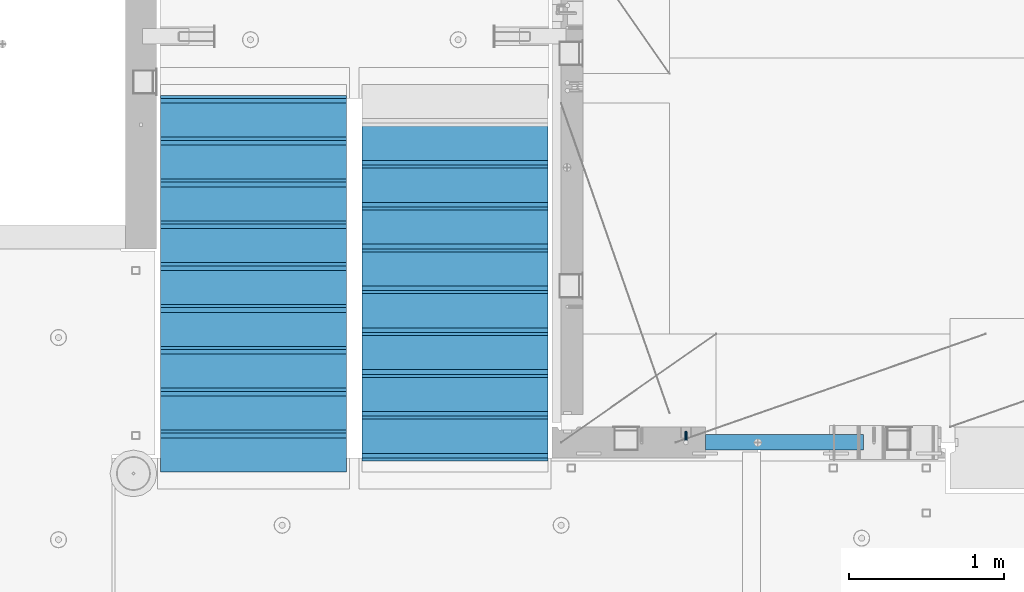
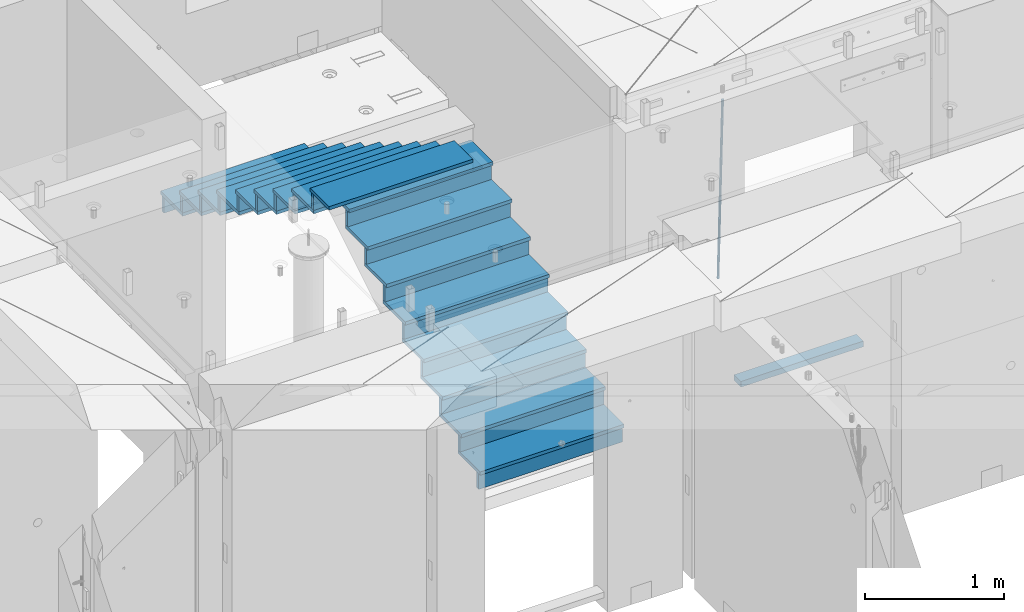
# One storey, part 119 of 350: 36 beams, 3 elements without a shape of their own.
"""IFC2X3 building model written with IfcOpenShell, lengths in millimetres."""

from ifc_helpers import new_model, si_unit, frame, origin_with_axes, place, context, subcontext, project, spatial, faceted_brep, material, type_object, element, aggregate, save


model = new_model("IFC2X3")

# Units and contexts
model_context = context("Model", 3, precision=1e-05, world=origin_with_axes())
body_context = subcontext(model_context, "Body", "Model", "MODEL_VIEW")
ifc_project = project(units=[si_unit("LENGTHUNIT", "METRE", prefix="MILLI"), si_unit("AREAUNIT", "SQUARE_METRE"), si_unit("VOLUMEUNIT", "CUBIC_METRE"), si_unit("MASSUNIT", "GRAM", prefix="KILO"), si_unit("TIMEUNIT", "SECOND"), si_unit("PLANEANGLEUNIT", "RADIAN"), si_unit("SOLIDANGLEUNIT", "STERADIAN"), si_unit("THERMODYNAMICTEMPERATUREUNIT", "DEGREE_CELSIUS"), si_unit("LUMINOUSINTENSITYUNIT", "LUMEN")], contexts=[model_context])

# Site, building, storey
site_placement = place(None, origin_with_axes())
site = spatial("IfcSite", under=ifc_project, at=site_placement, CompositionType="ELEMENT")
building_placement = place(site_placement, origin_with_axes())
building = spatial("IfcBuilding", under=site, at=building_placement, CompositionType="ELEMENT")
storey_placement = place(building_placement, origin_with_axes())
storey = spatial("IfcBuildingStorey", under=building, at=storey_placement, Name="2", CompositionType="ELEMENT", Elevation=0.0)

# Assembly, beams
assembly_1_placement = place(storey_placement, origin_with_axes())
assembly_1 = element("IfcElementAssembly", 1, at=assembly_1_placement, inside=storey, AssemblyPlace="NOTDEFINED", PredefinedType="REINFORCEMENT_UNIT")
ifc_material_1 = material()
beam_type_1 = type_object("IfcBeamType", Name="D20", PredefinedType="NOTDEFINED")
beam_1_placement = place(assembly_1_placement, frame((23075.0006866416, 17045.0000022791, 85790.0), z_axis=(0.00020576299992186, -0.999642804629538, -0.0267249099901004), x_axis=(-4.30000201928125e-08, -0.0267249099948059, 0.999642825806181)))
beam_1 = element("IfcBeam", 2, at=beam_1_placement, type_object=beam_type_1, material=ifc_material_1, Name="JM20", ObjectType="D20", context=body_context, shape_type="Brep", body=[
    faceted_brep([(0.0, -10.0, 0.0), (-4.19531716033816e-08, -7.07106781186667, -7.07106781187031), (60.4266690400545, -7.0710677960451, -7.07106780570757), (60.4266690441291, -9.99999998418934, 6.15546014159918e-09), (0.0, 0.0, -10.0), (60.426669036824, 1.58106558956206e-08, -9.99999999384454), (4.196772351861e-08, 7.07106781186303, -7.07106781186667), (60.4266690363438, 7.07106782768096, -7.07106780570757), (0.0, 10.0, 0.0), (60.4266690388904, 10.0000000158179, 6.15182216279209e-09), (4.196772351861e-08, 7.07106781185939, 7.07106781185939), (60.4266690429649, 7.07106782768096, 7.07106781802577), (0.0, 0.0, 10.0), (60.4266690461809, 1.58179318532348e-08, 10.0000000061555), (-4.19531716033816e-08, -7.07106781187031, 7.07106781185939), (60.4266690466611, -7.07106779605238, 7.07106781802213), (61.0378400410118, -7.07106779588503, -7.07106780564936), (60.991799419251, -9.99999998403655, 6.21366780251265e-09), (61.0569027789461, 1.5985278878361e-08, -9.99999999378269), (61.0378209396877, 7.07106782784831, -7.07106780564936), (60.9917724058905, 10.0000000159635, 6.21366780251265e-09), (60.9457317841297, 7.07106782781193, 7.0710678180767), (60.9266690461809, 1.59488990902901e-08, 10.0000000062028), (60.9457508854539, -7.07106779591413, 7.0710678180767), (61.6489592143771, -7.07106614513759, -7.06310863441468), (61.5568818710308, -9.9999984576425, 0.00735959856683621), (61.6870830769039, 1.71821739058942e-06, -9.99179257185824), (61.6489210170112, 7.07106947854481, -7.06310888312146), (61.556827851804, 10.0000015422847, 0.00735924683976918), (61.4647505084577, 7.07106922979438, 7.07782747982128), (61.4266266459163, 1.36643211590126e-06, 10.0065114172685), (61.464788705809, -7.07106639389531, 7.07782772852806), (176.543135720174, -7.07075579406956, -5.56673531796696), (176.451058376813, -9.99968810657447, 1.50373291501455), (176.581259582701, 0.000312069292704109, -8.49541925541052), (176.543097522794, 7.07137982961285, -5.56673556667374), (176.451004357587, 10.00031189336, 1.50373256329476), (176.35892701424, 7.07137958085514, 8.57420079627263), (176.320803151699, 0.000311717507429421, 11.5028847337162), (176.358965211621, -7.07075604281999, 8.57420104497578), (177.098753836006, -7.07075429323595, -5.55949898843028), (176.98362511232, -9.99968666800123, 1.510669025065), (177.146421932586, 0.000313595905026887, -8.48805862247536), (177.098706077581, 7.07138133041735, -5.55949936166144), (176.983557571715, 10.0003133318824, 1.51066849724157), (176.868428848029, 7.07138095712435, 8.58083651073321), (176.820760751449, 0.000313067976094317, 11.5093961447819), (176.868476606425, -7.07075466652896, 8.58083688396073), (177.654312950661, -7.07075204110879, -5.54863964998367), (177.516135294456, -9.99968450931192, 1.52107783331303), (177.711524267797, 0.000315886711177882, -8.47701274570863), (177.654255632195, 7.07138358250813, -5.54864021007961), (177.516054233929, 10.0003154905207, 1.5210770412159), (177.377876577739, 7.0713830223176, 8.59079452451624), (177.320665260588, 0.000315094497636892, 11.5191676202448), (177.377933896176, -7.07075260129932, 8.59079508461218), (299.580241614967, -7.07025777803938, -3.16539205229128), (299.442063958748, -9.99919024624614, 3.90432543100542), (299.637452932104, 0.000810149780591019, -6.09376514801625), (299.58018429653, 7.07187784557391, -3.16539261238358), (299.441982898265, 10.0008097535901, 3.90432463891557), (299.303805242045, 7.07187728538338, 10.974042122205), (299.246593924894, 0.00080935756341205, 13.9024152179336), (299.303862560482, -7.07025833822991, 10.9740426822973), (300.088882651282, -7.07025571611666, -3.15544980669438), (299.971788958996, -9.99918809853989, 3.91467979818117), (300.137357441272, 0.000812176291219657, -6.0839936725497), (300.088834180511, 7.07187990754028, -3.15545019384081), (299.971753863239, 10.0008119014747, 3.91467990454839), (299.854660170953, 7.07187951844026, 10.9848095094276), (299.806185380992, 0.000811626032373169, 13.9133533752902), (299.854708641738, -7.07025610520941, 10.9848098965813), (300.597573977022, -7.07025429077839, -3.14854421417112), (300.501599787152, -9.99918661431002, 3.92187219230618), (300.637311376035, 0.00081357714952901, -6.07720669196715), (300.597534354776, 7.07188133290401, -3.14854448120241), (300.501543752835, 10.0008133856099, 3.92187181466215), (300.40556956298, 7.07188106207104, 10.9922882211395), (300.365832163967, 0.000813194146758178, 13.9209506989318), (300.405609185211, -7.07025456160045, 10.9922884881707), (1494.60304651056, -7.06690872122999, 13.060333041718), (1494.50707232069, -9.99584104476162, 20.1307494481916), (1494.64278390956, 0.00415914670156781, 10.1316705639183), (1494.6030068883, 7.07522690244878, 13.0603327746867), (1494.50701628637, 10.004158955162, 20.1307490705476), (1494.4110420965, 7.07522663162308, 27.2011654770249), (1494.3713046975, 0.00415876370243495, 30.1298279548209), (1494.41108171875, -7.06690899205205, 27.2011657440526), (1495.1211563645, -7.06690726950183, 13.067366492749), (1495.00702625545, -9.99583964390331, 20.1375364287742), (1495.20660775043, 0.00416072652296862, 10.1393245920117), (1495.21332415029, 7.07522861253892, 13.0686179608165), (1495.13737118813, 10.0041607213934, 20.1393062718889), (1495.02324107911, 7.07522834699193, 27.2094762079141), (1494.93778969315, 0.00416035097441636, 30.1375181086514), (1494.93107329329, -7.06690753504881, 27.2082247398503), (1495.63922435709, -7.07365070849846, 13.0742491942874), (1495.5069397148, -10.00235861486, 20.1441724282631), (1495.77038591086, -0.00317370150150964, 10.1468279224828), (1495.82359171678, 7.06728286786529, 13.0767522910828), (1495.76767453534, 9.99594143344802, 20.1477123416917), (1495.63538989302, 7.0672335270865, 27.2176355756565), (1495.50422833927, -0.00324347991045215, 30.1450568474684), (1495.45102253335, -7.07370004928453, 27.2151324788683), (1517.48046966468, -7.35846502584536, 13.3649345949125), (1517.34818502239, -10.2871729322142, 20.4348578288809), (1517.61163121845, -0.287988018848409, 10.4375133231042), (1517.66483702436, 6.78246855052203, 13.3674376917079), (1517.60891984291, 9.71112711610476, 20.4383977423167), (1517.47663520063, 6.78241920973232, 27.5083209762815), (1517.34547364687, -0.288057797257352, 30.4357422480862), (1517.29226784095, -7.35851436663143, 27.5058178794898), (1518.11590717161, -7.36675126123009, 13.3733916404526), (1518.00827439407, -10.295780632965, 20.4436429663911), (1518.18994308249, -0.295529324139352, 10.4452100827657), (1518.18701289421, 6.77565927010801, 13.3743873367348), (1518.10883307132, 9.70460814510079, 20.4450510935785), (1518.00120029377, 6.77557877335857, 27.515302419517), (1517.9271643829, -0.295643163732166, 30.4434839772002), (1517.93009457119, -7.36683175797953, 27.5143067232275), (1518.75139849893, -7.36487536471395, 13.3816537936873), (1518.66841952164, -10.2938120781764, 20.4522328350286), (1518.76830418318, -0.293831718903675, 10.452712053142), (1518.7092334538, 6.77719739167878, 13.3811419616068), (1518.60878914295, 9.7060990139762, 20.4515089951637), (1518.52581016565, 6.77716230052101, 27.522088036505), (1518.50890448141, -0.293881345296541, 30.4510297770539), (1518.56797521077, -7.36491045587172, 27.5225998685855), (1618.77218426704, -7.06661321754655, 14.6790318180938), (1618.68920528975, -9.99554993101265, 21.7496108594387), (1618.78908995127, 0.0044304282637313, 11.7500900775485), (1618.73001922191, 7.07545953884255, 14.6785199860096), (1618.62957491104, 10.0043611611436, 21.748887019563), (1618.54659593375, 7.07542444768478, 28.8194660609042), (1618.52969024952, 0.00438080187086598, 31.7484078014531), (1618.58876097888, -7.06664830870795, 28.819977892992)], [[[0, 1, 2, 3]], [[1, 4, 5, 2]], [[4, 6, 7, 5]], [[6, 8, 9, 7]], [[8, 10, 11, 9]], [[10, 12, 13, 11]], [[12, 14, 15, 13]], [[14, 0, 3, 15]], [[14, 12, 10, 8, 6, 4, 1, 0]], [[3, 2, 16, 17]], [[2, 5, 18, 16]], [[5, 7, 19, 18]], [[7, 9, 20, 19]], [[9, 11, 21, 20]], [[11, 13, 22, 21]], [[13, 15, 23, 22]], [[15, 3, 17, 23]], [[17, 16, 24, 25]], [[16, 18, 26, 24]], [[18, 19, 27, 26]], [[19, 20, 28, 27]], [[20, 21, 29, 28]], [[21, 22, 30, 29]], [[22, 23, 31, 30]], [[23, 17, 25, 31]], [[25, 24, 32, 33]], [[24, 26, 34, 32]], [[26, 27, 35, 34]], [[27, 28, 36, 35]], [[28, 29, 37, 36]], [[29, 30, 38, 37]], [[30, 31, 39, 38]], [[31, 25, 33, 39]], [[33, 32, 40, 41]], [[32, 34, 42, 40]], [[34, 35, 43, 42]], [[35, 36, 44, 43]], [[36, 37, 45, 44]], [[37, 38, 46, 45]], [[38, 39, 47, 46]], [[39, 33, 41, 47]], [[41, 40, 48, 49]], [[40, 42, 50, 48]], [[42, 43, 51, 50]], [[43, 44, 52, 51]], [[44, 45, 53, 52]], [[45, 46, 54, 53]], [[46, 47, 55, 54]], [[47, 41, 49, 55]], [[49, 48, 56, 57]], [[48, 50, 58, 56]], [[50, 51, 59, 58]], [[51, 52, 60, 59]], [[52, 53, 61, 60]], [[53, 54, 62, 61]], [[54, 55, 63, 62]], [[55, 49, 57, 63]], [[57, 56, 64, 65]], [[56, 58, 66, 64]], [[58, 59, 67, 66]], [[59, 60, 68, 67]], [[60, 61, 69, 68]], [[61, 62, 70, 69]], [[62, 63, 71, 70]], [[63, 57, 65, 71]], [[65, 64, 72, 73]], [[64, 66, 74, 72]], [[66, 67, 75, 74]], [[67, 68, 76, 75]], [[68, 69, 77, 76]], [[69, 70, 78, 77]], [[70, 71, 79, 78]], [[71, 65, 73, 79]], [[73, 72, 80, 81]], [[72, 74, 82, 80]], [[74, 75, 83, 82]], [[75, 76, 84, 83]], [[76, 77, 85, 84]], [[77, 78, 86, 85]], [[78, 79, 87, 86]], [[79, 73, 81, 87]], [[81, 80, 88, 89]], [[80, 82, 90, 88]], [[82, 83, 91, 90]], [[83, 84, 92, 91]], [[84, 85, 93, 92]], [[85, 86, 94, 93]], [[86, 87, 95, 94]], [[87, 81, 89, 95]], [[89, 88, 96, 97]], [[88, 90, 98, 96]], [[90, 91, 99, 98]], [[91, 92, 100, 99]], [[92, 93, 101, 100]], [[93, 94, 102, 101]], [[94, 95, 103, 102]], [[95, 89, 97, 103]], [[97, 96, 104, 105]], [[96, 98, 106, 104]], [[98, 99, 107, 106]], [[99, 100, 108, 107]], [[100, 101, 109, 108]], [[101, 102, 110, 109]], [[102, 103, 111, 110]], [[103, 97, 105, 111]], [[105, 104, 112, 113]], [[104, 106, 114, 112]], [[106, 107, 115, 114]], [[107, 108, 116, 115]], [[108, 109, 117, 116]], [[109, 110, 118, 117]], [[110, 111, 119, 118]], [[111, 105, 113, 119]], [[113, 112, 120, 121]], [[112, 114, 122, 120]], [[114, 115, 123, 122]], [[115, 116, 124, 123]], [[116, 117, 125, 124]], [[117, 118, 126, 125]], [[118, 119, 127, 126]], [[119, 113, 121, 127]], [[121, 120, 128, 129]], [[120, 122, 130, 128]], [[122, 123, 131, 130]], [[123, 124, 132, 131]], [[124, 125, 133, 132]], [[125, 126, 134, 133]], [[126, 127, 135, 134]], [[127, 121, 129, 135]], [[130, 131, 132, 133, 134, 135, 129, 128]]]),
])
ifc_material_2 = material(Name="TIMBER/T24")
beam_type_2 = type_object("IfcBeamType", PredefinedType="NOTDEFINED")
beam_2_placement = place(assembly_1_placement, frame((23200.0006866455, 16980.0, 84880.0), z_axis=(0.0, 0.0, 1.0), x_axis=(1.0, 0.0, 0.0)))
beam_2 = element("IfcBeam", 3, at=beam_2_placement, type_object=beam_type_2, material=ifc_material_2, context=body_context, shape_type="Brep", body=[
    faceted_brep([(0.0, 50.0, -25.0), (0.0, 50.0, 25.0), (1020.0, 50.0, 25.0), (1020.0, 50.0, -25.0), (0.0, -50.0, 25.0), (1020.0, -50.0, 25.0), (0.0, -50.0, -25.0), (1020.0, -50.0, -25.0)], [[[0, 1, 2, 3]], [[1, 4, 5, 2]], [[4, 6, 7, 5]], [[6, 0, 3, 7]], [[5, 7, 3, 2]], [[6, 4, 1, 0]]]),
])
aggregate(assembly_1, [beam_1, beam_2])

assembly_2_placement = place(storey_placement, origin_with_axes())
assembly_2 = element("IfcElementAssembly", 4, at=assembly_2_placement, inside=storey, Name="E9", AssemblyPlace="NOTDEFINED", PredefinedType="NOTDEFINED")
ifc_material_3 = material(Name="Undefined/C32/40")
beam_type_3 = type_object("IfcBeamType", PredefinedType="NOTDEFINED")
beam_3_placement = place(assembly_2_placement, frame((20885.0002457424, 17024.9998138874, 87662.1), z_axis=(0.0, 1.0, 0.0), x_axis=(-1.0, 3.00000001838171e-08, 0.0)))
beam_3 = element("IfcBeam", 5, at=beam_3_placement, type_object=beam_type_3, material=ifc_material_3, Name="E9", context=body_context, shape_type="Brep", body=[
    faceted_brep([(0.0, 68.5, -15.0), (0.0, 68.5, 15.0), (1200.0, 68.5, 15.0), (1200.0, 68.5, -15.0), (0.0, -68.5, 15.0), (1200.0, -68.5, 15.0), (0.0, -68.5, -15.0), (1200.0, -68.5, -15.0)], [[[0, 1, 2, 3]], [[1, 4, 5, 2]], [[4, 6, 7, 5]], [[6, 0, 3, 7]], [[5, 7, 3, 2]], [[6, 4, 1, 0]]]),
])
beam_4_placement = place(assembly_2_placement, frame((20885.0002457424, 17294.9998138874, 87495.4), z_axis=(0.0, 1.0, 0.0), x_axis=(-1.0, 3.00000001838171e-08, 0.0)))
beam_4 = element("IfcBeam", 6, at=beam_4_placement, type_object=beam_type_3, material=ifc_material_3, Name="E9", context=body_context, shape_type="Brep", body=[
    faceted_brep([(0.0, 68.5, -15.0), (0.0, 68.5, 15.0), (1200.0, 68.5, 15.0), (1200.0, 68.5, -15.0), (0.0, -68.5, 15.0), (1200.0, -68.5, 15.0), (0.0, -68.5, -15.0), (1200.0, -68.5, -15.0)], [[[0, 1, 2, 3]], [[1, 4, 5, 2]], [[4, 6, 7, 5]], [[6, 0, 3, 7]], [[5, 7, 3, 2]], [[6, 4, 1, 0]]]),
])
beam_5_placement = place(assembly_2_placement, frame((20885.0002457424, 17564.9998138874, 87328.7), z_axis=(0.0, 1.0, 0.0), x_axis=(-1.0, 3.00000001838171e-08, 0.0)))
beam_5 = element("IfcBeam", 7, at=beam_5_placement, type_object=beam_type_3, material=ifc_material_3, Name="E9", context=body_context, shape_type="Brep", body=[
    faceted_brep([(0.0, 68.5, -15.0), (0.0, 68.5, 15.0), (1200.0, 68.5, 15.0), (1200.0, 68.5, -15.0), (0.0, -68.5, 15.0), (1200.0, -68.5, 15.0), (0.0, -68.5, -15.0), (1200.0, -68.5, -15.0)], [[[0, 1, 2, 3]], [[1, 4, 5, 2]], [[4, 6, 7, 5]], [[6, 0, 3, 7]], [[5, 7, 3, 2]], [[6, 4, 1, 0]]]),
])
beam_6_placement = place(assembly_2_placement, frame((20885.0002457424, 17834.9998138874, 87162.0), z_axis=(0.0, 1.0, 0.0), x_axis=(-1.0, 3.00000001838171e-08, 0.0)))
beam_6 = element("IfcBeam", 8, at=beam_6_placement, type_object=beam_type_3, material=ifc_material_3, Name="E9", context=body_context, shape_type="Brep", body=[
    faceted_brep([(0.0, 68.5, -15.0), (0.0, 68.5, 15.0), (1200.0, 68.5, 15.0), (1200.0, 68.5, -15.0), (0.0, -68.5, 15.0), (1200.0, -68.5, 15.0), (0.0, -68.5, -15.0), (1200.0, -68.5, -15.0)], [[[0, 1, 2, 3]], [[1, 4, 5, 2]], [[4, 6, 7, 5]], [[6, 0, 3, 7]], [[5, 7, 3, 2]], [[6, 4, 1, 0]]]),
])
beam_7_placement = place(assembly_2_placement, frame((20885.0002457424, 18104.9998138874, 86995.3), z_axis=(0.0, 1.0, 0.0), x_axis=(-1.0, 3.00000001838171e-08, 0.0)))
beam_7 = element("IfcBeam", 9, at=beam_7_placement, type_object=beam_type_3, material=ifc_material_3, Name="E9", context=body_context, shape_type="Brep", body=[
    faceted_brep([(0.0, 68.5, -15.0), (0.0, 68.5, 15.0), (1200.0, 68.5, 15.0), (1200.0, 68.5, -15.0), (0.0, -68.5, 15.0), (1200.0, -68.5, 15.0), (0.0, -68.5, -15.0), (1200.0, -68.5, -15.0)], [[[0, 1, 2, 3]], [[1, 4, 5, 2]], [[4, 6, 7, 5]], [[6, 0, 3, 7]], [[5, 7, 3, 2]], [[6, 4, 1, 0]]]),
])
beam_8_placement = place(assembly_2_placement, frame((20885.0002457424, 18374.9998138874, 86828.6), z_axis=(0.0, 1.0, 0.0), x_axis=(-1.0, 3.00000001838171e-08, 0.0)))
beam_8 = element("IfcBeam", 10, at=beam_8_placement, type_object=beam_type_3, material=ifc_material_3, Name="E9", context=body_context, shape_type="Brep", body=[
    faceted_brep([(0.0, 68.5, -15.0), (0.0, 68.5, 15.0), (1200.0, 68.5, 15.0), (1200.0, 68.5, -15.0), (0.0, -68.5, 15.0), (1200.0, -68.5, 15.0), (0.0, -68.5, -15.0), (1200.0, -68.5, -15.0)], [[[0, 1, 2, 3]], [[1, 4, 5, 2]], [[4, 6, 7, 5]], [[6, 0, 3, 7]], [[5, 7, 3, 2]], [[6, 4, 1, 0]]]),
])
beam_9_placement = place(assembly_2_placement, frame((20885.0002457424, 18644.9998138874, 86661.9), z_axis=(0.0, 1.0, 0.0), x_axis=(-1.0, 3.00000001838171e-08, 0.0)))
beam_9 = element("IfcBeam", 11, at=beam_9_placement, type_object=beam_type_3, material=ifc_material_3, Name="E9", context=body_context, shape_type="Brep", body=[
    faceted_brep([(0.0, 68.5, -15.0), (0.0, 68.5, 15.0), (1200.0, 68.5, 15.0), (1200.0, 68.5, -15.0), (0.0, -68.5, 15.0), (1200.0, -68.5, 15.0), (0.0, -68.5, -15.0), (1200.0, -68.5, -15.0)], [[[0, 1, 2, 3]], [[1, 4, 5, 2]], [[4, 6, 7, 5]], [[6, 0, 3, 7]], [[5, 7, 3, 2]], [[6, 4, 1, 0]]]),
])
beam_10_placement = place(assembly_2_placement, frame((20885.0002457424, 18914.9998138874, 86495.2), z_axis=(0.0, 1.0, 0.0), x_axis=(-1.0, 3.00000001838171e-08, 0.0)))
beam_10 = element("IfcBeam", 12, at=beam_10_placement, type_object=beam_type_3, material=ifc_material_3, Name="E9", context=body_context, shape_type="Brep", body=[
    faceted_brep([(0.0, 68.5, -15.0), (0.0, 68.5, 15.0), (1200.0, 68.5, 15.0), (1200.0, 68.5, -15.0), (0.0, -68.5, 15.0), (1200.0, -68.5, 15.0), (0.0, -68.5, -15.0), (1200.0, -68.5, -15.0)], [[[0, 1, 2, 3]], [[1, 4, 5, 2]], [[4, 6, 7, 5]], [[6, 0, 3, 7]], [[5, 7, 3, 2]], [[6, 4, 1, 0]]]),
])
beam_11_placement = place(assembly_2_placement, frame((20885.0002457424, 19184.9998138874, 86328.5), z_axis=(0.0, 1.0, 0.0), x_axis=(-1.0, 3.00000001838171e-08, 0.0)))
beam_11 = element("IfcBeam", 13, at=beam_11_placement, type_object=beam_type_3, material=ifc_material_3, Name="E9", context=body_context, shape_type="Brep", body=[
    faceted_brep([(0.0, 68.5, -15.0), (0.0, 68.5, 15.0), (1200.0, 68.5, 15.0), (1200.0, 68.5, -15.0), (0.0, -68.5, 15.0), (1200.0, -68.5, 15.0), (0.0, -68.5, -15.0), (1200.0, -68.5, -15.0)], [[[0, 1, 2, 3]], [[1, 4, 5, 2]], [[4, 6, 7, 5]], [[6, 0, 3, 7]], [[5, 7, 3, 2]], [[6, 4, 1, 0]]]),
])

assembly_3_placement = place(storey_placement, origin_with_axes())
assembly_3 = element("IfcElementAssembly", 14, at=assembly_3_placement, inside=storey, Name="E9", AssemblyPlace="NOTDEFINED", PredefinedType="NOTDEFINED")
beam_12_placement = place(assembly_3_placement, frame((20985.002175553, 18785.001025346, 85995.1036072969), z_axis=(0.0, -1.0, 0.0), x_axis=(1.0, 0.0, 0.0)))
beam_12 = element("IfcBeam", 15, at=beam_12_placement, type_object=beam_type_3, material=ifc_material_3, Name="E9", context=body_context, shape_type="Brep", body=[
    faceted_brep([(0.0, 68.5, -15.0), (0.0, 68.5, 15.0), (1200.0, 68.5, 15.0), (1200.0, 68.5, -15.0), (0.0, -68.5, 15.0), (1200.0, -68.5, 15.0), (0.0, -68.5, -15.0), (1200.0, -68.5, -15.0)], [[[0, 1, 2, 3]], [[1, 4, 5, 2]], [[4, 6, 7, 5]], [[6, 0, 3, 7]], [[5, 7, 3, 2]], [[6, 4, 1, 0]]]),
])
beam_13_placement = place(assembly_3_placement, frame((20985.002175553, 18515.001025346, 85828.4036072969), z_axis=(0.0, -1.0, 0.0), x_axis=(1.0, 0.0, 0.0)))
beam_13 = element("IfcBeam", 16, at=beam_13_placement, type_object=beam_type_3, material=ifc_material_3, Name="E9", context=body_context, shape_type="Brep", body=[
    faceted_brep([(0.0, 68.5, -15.0), (0.0, 68.5, 15.0), (1200.0, 68.5, 15.0), (1200.0, 68.5, -15.0), (0.0, -68.5, 15.0), (1200.0, -68.5, 15.0), (0.0, -68.5, -15.0), (1200.0, -68.5, -15.0)], [[[0, 1, 2, 3]], [[1, 4, 5, 2]], [[4, 6, 7, 5]], [[6, 0, 3, 7]], [[5, 7, 3, 2]], [[6, 4, 1, 0]]]),
])
beam_14_placement = place(assembly_3_placement, frame((20985.002175553, 18245.001025346, 85661.7036072969), z_axis=(0.0, -1.0, 0.0), x_axis=(1.0, 0.0, 0.0)))
beam_14 = element("IfcBeam", 17, at=beam_14_placement, type_object=beam_type_3, material=ifc_material_3, Name="E9", context=body_context, shape_type="Brep", body=[
    faceted_brep([(0.0, 68.5, -15.0), (0.0, 68.5, 15.0), (1200.0, 68.5, 15.0), (1200.0, 68.5, -15.0), (0.0, -68.5, 15.0), (1200.0, -68.5, 15.0), (0.0, -68.5, -15.0), (1200.0, -68.5, -15.0)], [[[0, 1, 2, 3]], [[1, 4, 5, 2]], [[4, 6, 7, 5]], [[6, 0, 3, 7]], [[5, 7, 3, 2]], [[6, 4, 1, 0]]]),
])
beam_15_placement = place(assembly_3_placement, frame((20985.002175553, 17975.001025346, 85495.0036072969), z_axis=(0.0, -1.0, 0.0), x_axis=(1.0, 0.0, 0.0)))
beam_15 = element("IfcBeam", 18, at=beam_15_placement, type_object=beam_type_3, material=ifc_material_3, Name="E9", context=body_context, shape_type="Brep", body=[
    faceted_brep([(0.0, 68.5, -15.0), (0.0, 68.5, 15.0), (1200.0, 68.5, 15.0), (1200.0, 68.5, -15.0), (0.0, -68.5, 15.0), (1200.0, -68.5, 15.0), (0.0, -68.5, -15.0), (1200.0, -68.5, -15.0)], [[[0, 1, 2, 3]], [[1, 4, 5, 2]], [[4, 6, 7, 5]], [[6, 0, 3, 7]], [[5, 7, 3, 2]], [[6, 4, 1, 0]]]),
])
beam_16_placement = place(assembly_3_placement, frame((20985.002175553, 17705.001025346, 85328.3036072969), z_axis=(0.0, -1.0, 0.0), x_axis=(1.0, 0.0, 0.0)))
beam_16 = element("IfcBeam", 19, at=beam_16_placement, type_object=beam_type_3, material=ifc_material_3, Name="E9", context=body_context, shape_type="Brep", body=[
    faceted_brep([(0.0, 68.5, -15.0), (0.0, 68.5, 15.0), (1200.0, 68.5, 15.0), (1200.0, 68.5, -15.0), (0.0, -68.5, 15.0), (1200.0, -68.5, 15.0), (0.0, -68.5, -15.0), (1200.0, -68.5, -15.0)], [[[0, 1, 2, 3]], [[1, 4, 5, 2]], [[4, 6, 7, 5]], [[6, 0, 3, 7]], [[5, 7, 3, 2]], [[6, 4, 1, 0]]]),
])
beam_17_placement = place(assembly_3_placement, frame((20985.002175553, 17435.001025346, 85161.6036072969), z_axis=(0.0, -1.0, 0.0), x_axis=(1.0, 0.0, 0.0)))
beam_17 = element("IfcBeam", 20, at=beam_17_placement, type_object=beam_type_3, material=ifc_material_3, Name="E9", context=body_context, shape_type="Brep", body=[
    faceted_brep([(0.0, 68.5, -15.0), (0.0, 68.5, 15.0), (1200.0, 68.5, 15.0), (1200.0, 68.5, -15.0), (0.0, -68.5, 15.0), (1200.0, -68.5, 15.0), (0.0, -68.5, -15.0), (1200.0, -68.5, -15.0)], [[[0, 1, 2, 3]], [[1, 4, 5, 2]], [[4, 6, 7, 5]], [[6, 0, 3, 7]], [[5, 7, 3, 2]], [[6, 4, 1, 0]]]),
])
beam_18_placement = place(assembly_3_placement, frame((20985.002175553, 17165.001025346, 84994.9036072969), z_axis=(0.0, -1.0, 0.0), x_axis=(1.0, 0.0, 0.0)))
beam_18 = element("IfcBeam", 21, at=beam_18_placement, type_object=beam_type_3, material=ifc_material_3, Name="E9", context=body_context, shape_type="Brep", body=[
    faceted_brep([(0.0, 68.5, -15.0), (0.0, 68.5, 15.0), (1200.0, 68.5, 15.0), (1200.0, 68.5, -15.0), (0.0, -68.5, 15.0), (1200.0, -68.5, 15.0), (0.0, -68.5, -15.0), (1200.0, -68.5, -15.0)], [[[0, 1, 2, 3]], [[1, 4, 5, 2]], [[4, 6, 7, 5]], [[6, 0, 3, 7]], [[5, 7, 3, 2]], [[6, 4, 1, 0]]]),
])
beam_19_placement = place(assembly_3_placement, frame((20985.002175553, 16895.001025346, 84828.2036072969), z_axis=(0.0, -1.0, 0.0), x_axis=(1.0, 0.0, 0.0)))
beam_19 = element("IfcBeam", 22, at=beam_19_placement, type_object=beam_type_3, material=ifc_material_3, Name="E9", context=body_context, shape_type="Brep", body=[
    faceted_brep([(0.0, 68.5, -15.0), (0.0, 68.5, 15.0), (1200.0, 68.5, 15.0), (1200.0, 68.5, -15.0), (0.0, -68.5, 15.0), (1200.0, -68.5, 15.0), (0.0, -68.5, -15.0), (1200.0, -68.5, -15.0)], [[[0, 1, 2, 3]], [[1, 4, 5, 2]], [[4, 6, 7, 5]], [[6, 0, 3, 7]], [[5, 7, 3, 2]], [[6, 4, 1, 0]]]),
])

# Beam
beam_type_4 = type_object("IfcBeamType", PredefinedType="NOTDEFINED")
beam_20_placement = place(assembly_2_placement, frame((20885.0002457424, 17169.9998138874, 87578.6), z_axis=(0.0, 1.0, 0.0), x_axis=(-1.0, 3.00000001838171e-08, 0.0)))
beam_20 = element("IfcBeam", 23, at=beam_20_placement, type_object=beam_type_4, material=ifc_material_3, Name="E9", context=body_context, shape_type="Brep", body=[
    faceted_brep([(0.0, 15.0, -160.0), (0.0, 15.0, 160.0), (1200.0, 15.0, 160.0), (1200.0, 15.0, -160.0), (0.0, -15.0, 160.0), (1200.0, -15.0, 160.0), (0.0, -15.0, -160.0), (1200.0, -15.0, -160.0)], [[[0, 1, 2, 3]], [[1, 4, 5, 2]], [[4, 6, 7, 5]], [[6, 0, 3, 7]], [[5, 7, 3, 2]], [[6, 4, 1, 0]]]),
])

beam_21_placement = place(assembly_2_placement, frame((20885.0002457424, 17439.9998138874, 87411.9), z_axis=(0.0, 1.0, 0.0), x_axis=(-1.0, 3.00000001838171e-08, 0.0)))
beam_21 = element("IfcBeam", 24, at=beam_21_placement, type_object=beam_type_4, material=ifc_material_3, Name="E9", context=body_context, shape_type="Brep", body=[
    faceted_brep([(0.0, 15.0, -160.0), (0.0, 15.0, 160.0), (1200.0, 15.0, 160.0), (1200.0, 15.0, -160.0), (0.0, -15.0, 160.0), (1200.0, -15.0, 160.0), (0.0, -15.0, -160.0), (1200.0, -15.0, -160.0)], [[[0, 1, 2, 3]], [[1, 4, 5, 2]], [[4, 6, 7, 5]], [[6, 0, 3, 7]], [[5, 7, 3, 2]], [[6, 4, 1, 0]]]),
])

beam_22_placement = place(assembly_2_placement, frame((20885.0002457424, 17709.9998138874, 87245.2), z_axis=(0.0, 1.0, 0.0), x_axis=(-1.0, 3.00000001838171e-08, 0.0)))
beam_22 = element("IfcBeam", 25, at=beam_22_placement, type_object=beam_type_4, material=ifc_material_3, Name="E9", context=body_context, shape_type="Brep", body=[
    faceted_brep([(0.0, 15.0, -160.0), (0.0, 15.0, 160.0), (1200.0, 15.0, 160.0), (1200.0, 15.0, -160.0), (0.0, -15.0, 160.0), (1200.0, -15.0, 160.0), (0.0, -15.0, -160.0), (1200.0, -15.0, -160.0)], [[[0, 1, 2, 3]], [[1, 4, 5, 2]], [[4, 6, 7, 5]], [[6, 0, 3, 7]], [[5, 7, 3, 2]], [[6, 4, 1, 0]]]),
])

beam_23_placement = place(assembly_2_placement, frame((20885.0002457424, 17979.9998138874, 87078.5), z_axis=(0.0, 1.0, 0.0), x_axis=(-1.0, 3.00000001838171e-08, 0.0)))
beam_23 = element("IfcBeam", 26, at=beam_23_placement, type_object=beam_type_4, material=ifc_material_3, Name="E9", context=body_context, shape_type="Brep", body=[
    faceted_brep([(0.0, 15.0, -160.0), (0.0, 15.0, 160.0), (1200.0, 15.0, 160.0), (1200.0, 15.0, -160.0), (0.0, -15.0, 160.0), (1200.0, -15.0, 160.0), (0.0, -15.0, -160.0), (1200.0, -15.0, -160.0)], [[[0, 1, 2, 3]], [[1, 4, 5, 2]], [[4, 6, 7, 5]], [[6, 0, 3, 7]], [[5, 7, 3, 2]], [[6, 4, 1, 0]]]),
])

beam_24_placement = place(assembly_2_placement, frame((20885.0002457424, 18249.9998138874, 86911.8), z_axis=(0.0, 1.0, 0.0), x_axis=(-1.0, 3.00000001838171e-08, 0.0)))
beam_24 = element("IfcBeam", 27, at=beam_24_placement, type_object=beam_type_4, material=ifc_material_3, Name="E9", context=body_context, shape_type="Brep", body=[
    faceted_brep([(0.0, 15.0, -160.0), (0.0, 15.0, 160.0), (1200.0, 15.0, 160.0), (1200.0, 15.0, -160.0), (0.0, -15.0, 160.0), (1200.0, -15.0, 160.0), (0.0, -15.0, -160.0), (1200.0, -15.0, -160.0)], [[[0, 1, 2, 3]], [[1, 4, 5, 2]], [[4, 6, 7, 5]], [[6, 0, 3, 7]], [[5, 7, 3, 2]], [[6, 4, 1, 0]]]),
])

beam_25_placement = place(assembly_2_placement, frame((20885.0002457424, 18519.9998138874, 86745.1), z_axis=(0.0, 1.0, 0.0), x_axis=(-1.0, 3.00000001838171e-08, 0.0)))
beam_25 = element("IfcBeam", 28, at=beam_25_placement, type_object=beam_type_4, material=ifc_material_3, Name="E9", context=body_context, shape_type="Brep", body=[
    faceted_brep([(0.0, 15.0, -160.0), (0.0, 15.0, 160.0), (1200.0, 15.0, 160.0), (1200.0, 15.0, -160.0), (0.0, -15.0, 160.0), (1200.0, -15.0, 160.0), (0.0, -15.0, -160.0), (1200.0, -15.0, -160.0)], [[[0, 1, 2, 3]], [[1, 4, 5, 2]], [[4, 6, 7, 5]], [[6, 0, 3, 7]], [[5, 7, 3, 2]], [[6, 4, 1, 0]]]),
])

beam_26_placement = place(assembly_2_placement, frame((20885.0002457424, 18789.9998138874, 86578.4), z_axis=(0.0, 1.0, 0.0), x_axis=(-1.0, 3.00000001838171e-08, 0.0)))
beam_26 = element("IfcBeam", 29, at=beam_26_placement, type_object=beam_type_4, material=ifc_material_3, Name="E9", context=body_context, shape_type="Brep", body=[
    faceted_brep([(0.0, 15.0, -160.0), (0.0, 15.0, 160.0), (1200.0, 15.0, 160.0), (1200.0, 15.0, -160.0), (0.0, -15.0, 160.0), (1200.0, -15.0, 160.0), (0.0, -15.0, -160.0), (1200.0, -15.0, -160.0)], [[[0, 1, 2, 3]], [[1, 4, 5, 2]], [[4, 6, 7, 5]], [[6, 0, 3, 7]], [[5, 7, 3, 2]], [[6, 4, 1, 0]]]),
])

beam_27_placement = place(assembly_2_placement, frame((20885.0002457424, 19059.9998138874, 86411.7), z_axis=(0.0, 1.0, 0.0), x_axis=(-1.0, 3.00000001838171e-08, 0.0)))
beam_27 = element("IfcBeam", 30, at=beam_27_placement, type_object=beam_type_4, material=ifc_material_3, Name="E9", context=body_context, shape_type="Brep", body=[
    faceted_brep([(0.0, 15.0, -160.0), (0.0, 15.0, 160.0), (1200.0, 15.0, 160.0), (1200.0, 15.0, -160.0), (0.0, -15.0, 160.0), (1200.0, -15.0, 160.0), (0.0, -15.0, -160.0), (1200.0, -15.0, -160.0)], [[[0, 1, 2, 3]], [[1, 4, 5, 2]], [[4, 6, 7, 5]], [[6, 0, 3, 7]], [[5, 7, 3, 2]], [[6, 4, 1, 0]]]),
])

beam_28_placement = place(assembly_3_placement, frame((20985.002175553, 18910.001025346, 86078.303607297), z_axis=(0.0, -1.0, 0.0), x_axis=(1.0, 0.0, 0.0)))
beam_28 = element("IfcBeam", 31, at=beam_28_placement, type_object=beam_type_4, material=ifc_material_3, Name="E9", context=body_context, shape_type="Brep", body=[
    faceted_brep([(0.0, 15.0, -160.0), (0.0, 15.0, 160.0), (1200.0, 15.0, 160.0), (1200.0, 15.0, -160.0), (0.0, -15.0, 160.0), (1200.0, -15.0, 160.0), (0.0, -15.0, -160.0), (1200.0, -15.0, -160.0)], [[[0, 1, 2, 3]], [[1, 4, 5, 2]], [[4, 6, 7, 5]], [[6, 0, 3, 7]], [[5, 7, 3, 2]], [[6, 4, 1, 0]]]),
])

beam_29_placement = place(assembly_3_placement, frame((20985.002175553, 18640.001025346, 85911.6036072969), z_axis=(0.0, -1.0, 0.0), x_axis=(1.0, 0.0, 0.0)))
beam_29 = element("IfcBeam", 32, at=beam_29_placement, type_object=beam_type_4, material=ifc_material_3, Name="E9", context=body_context, shape_type="Brep", body=[
    faceted_brep([(0.0, 15.0, -160.0), (0.0, 15.0, 160.0), (1200.0, 15.0, 160.0), (1200.0, 15.0, -160.0), (0.0, -15.0, 160.0), (1200.0, -15.0, 160.0), (0.0, -15.0, -160.0), (1200.0, -15.0, -160.0)], [[[0, 1, 2, 3]], [[1, 4, 5, 2]], [[4, 6, 7, 5]], [[6, 0, 3, 7]], [[5, 7, 3, 2]], [[6, 4, 1, 0]]]),
])

beam_30_placement = place(assembly_3_placement, frame((20985.002175553, 18370.001025346, 85744.9036072969), z_axis=(0.0, -1.0, 0.0), x_axis=(1.0, 0.0, 0.0)))
beam_30 = element("IfcBeam", 33, at=beam_30_placement, type_object=beam_type_4, material=ifc_material_3, Name="E9", context=body_context, shape_type="Brep", body=[
    faceted_brep([(0.0, 15.0, -160.0), (0.0, 15.0, 160.0), (1200.0, 15.0, 160.0), (1200.0, 15.0, -160.0), (0.0, -15.0, 160.0), (1200.0, -15.0, 160.0), (0.0, -15.0, -160.0), (1200.0, -15.0, -160.0)], [[[0, 1, 2, 3]], [[1, 4, 5, 2]], [[4, 6, 7, 5]], [[6, 0, 3, 7]], [[5, 7, 3, 2]], [[6, 4, 1, 0]]]),
])

beam_31_placement = place(assembly_3_placement, frame((20985.002175553, 18100.001025346, 85578.2036072969), z_axis=(0.0, -1.0, 0.0), x_axis=(1.0, 0.0, 0.0)))
beam_31 = element("IfcBeam", 34, at=beam_31_placement, type_object=beam_type_4, material=ifc_material_3, Name="E9", context=body_context, shape_type="Brep", body=[
    faceted_brep([(0.0, 15.0, -160.0), (0.0, 15.0, 160.0), (1200.0, 15.0, 160.0), (1200.0, 15.0, -160.0), (0.0, -15.0, 160.0), (1200.0, -15.0, 160.0), (0.0, -15.0, -160.0), (1200.0, -15.0, -160.0)], [[[0, 1, 2, 3]], [[1, 4, 5, 2]], [[4, 6, 7, 5]], [[6, 0, 3, 7]], [[5, 7, 3, 2]], [[6, 4, 1, 0]]]),
])

beam_32_placement = place(assembly_3_placement, frame((20985.002175553, 17830.001025346, 85411.5036072969), z_axis=(0.0, -1.0, 0.0), x_axis=(1.0, 0.0, 0.0)))
beam_32 = element("IfcBeam", 35, at=beam_32_placement, type_object=beam_type_4, material=ifc_material_3, Name="E9", context=body_context, shape_type="Brep", body=[
    faceted_brep([(0.0, 15.0, -160.0), (0.0, 15.0, 160.0), (1200.0, 15.0, 160.0), (1200.0, 15.0, -160.0), (0.0, -15.0, 160.0), (1200.0, -15.0, 160.0), (0.0, -15.0, -160.0), (1200.0, -15.0, -160.0)], [[[0, 1, 2, 3]], [[1, 4, 5, 2]], [[4, 6, 7, 5]], [[6, 0, 3, 7]], [[5, 7, 3, 2]], [[6, 4, 1, 0]]]),
])

beam_33_placement = place(assembly_3_placement, frame((20985.002175553, 17560.001025346, 85244.8036072969), z_axis=(0.0, -1.0, 0.0), x_axis=(1.0, 0.0, 0.0)))
beam_33 = element("IfcBeam", 36, at=beam_33_placement, type_object=beam_type_4, material=ifc_material_3, Name="E9", context=body_context, shape_type="Brep", body=[
    faceted_brep([(0.0, 15.0, -160.0), (0.0, 15.0, 160.0), (1200.0, 15.0, 160.0), (1200.0, 15.0, -160.0), (0.0, -15.0, 160.0), (1200.0, -15.0, 160.0), (0.0, -15.0, -160.0), (1200.0, -15.0, -160.0)], [[[0, 1, 2, 3]], [[1, 4, 5, 2]], [[4, 6, 7, 5]], [[6, 0, 3, 7]], [[5, 7, 3, 2]], [[6, 4, 1, 0]]]),
])

beam_34_placement = place(assembly_3_placement, frame((20985.002175553, 17290.001025346, 85078.1036072969), z_axis=(0.0, -1.0, 0.0), x_axis=(1.0, 0.0, 0.0)))
beam_34 = element("IfcBeam", 37, at=beam_34_placement, type_object=beam_type_4, material=ifc_material_3, Name="E9", context=body_context, shape_type="Brep", body=[
    faceted_brep([(0.0, 15.0, -160.0), (0.0, 15.0, 160.0), (1200.0, 15.0, 160.0), (1200.0, 15.0, -160.0), (0.0, -15.0, 160.0), (1200.0, -15.0, 160.0), (0.0, -15.0, -160.0), (1200.0, -15.0, -160.0)], [[[0, 1, 2, 3]], [[1, 4, 5, 2]], [[4, 6, 7, 5]], [[6, 0, 3, 7]], [[5, 7, 3, 2]], [[6, 4, 1, 0]]]),
])

beam_35_placement = place(assembly_3_placement, frame((20985.002175553, 17020.001025346, 84911.4036072969), z_axis=(0.0, -1.0, 0.0), x_axis=(1.0, 0.0, 0.0)))
beam_35 = element("IfcBeam", 38, at=beam_35_placement, type_object=beam_type_4, material=ifc_material_3, Name="E9", context=body_context, shape_type="Brep", body=[
    faceted_brep([(0.0, 15.0, -160.0), (0.0, 15.0, 160.0), (1200.0, 15.0, 160.0), (1200.0, 15.0, -160.0), (0.0, -15.0, 160.0), (1200.0, -15.0, 160.0), (0.0, -15.0, -160.0), (1200.0, -15.0, -160.0)], [[[0, 1, 2, 3]], [[1, 4, 5, 2]], [[4, 6, 7, 5]], [[6, 0, 3, 7]], [[5, 7, 3, 2]], [[6, 4, 1, 0]]]),
])

aggregate(assembly_3, [beam_28, beam_12, beam_29, beam_13, beam_30, beam_14, beam_31, beam_15, beam_32, beam_16, beam_33, beam_17, beam_34, beam_18, beam_35, beam_19])

beam_type_5 = type_object("IfcBeamType", PredefinedType="NOTDEFINED")
beam_36_placement = place(assembly_2_placement, frame((20885.0002457424, 16924.9998138874, 87745.3), z_axis=(0.0, 1.0, 0.0), x_axis=(-1.0, 3.00000001838171e-08, 0.0)))
beam_36 = element("IfcBeam", 39, at=beam_36_placement, type_object=beam_type_5, material=ifc_material_3, Name="E9", context=body_context, shape_type="Brep", body=[
    faceted_brep([(0.0, 15.0, -135.0), (0.0, 15.0, 135.0), (1200.0, 15.0, 135.0), (1200.0, 15.0, -135.0), (0.0, -15.0, 135.0), (1200.0, -15.0, 135.0), (0.0, -15.0, -135.0), (1200.0, -15.0, -135.0)], [[[0, 1, 2, 3]], [[1, 4, 5, 2]], [[4, 6, 7, 5]], [[6, 0, 3, 7]], [[5, 7, 3, 2]], [[6, 4, 1, 0]]]),
])

aggregate(assembly_2, [beam_3, beam_20, beam_4, beam_21, beam_5, beam_22, beam_6, beam_23, beam_7, beam_24, beam_8, beam_25, beam_9, beam_26, beam_10, beam_27, beam_36, beam_11])

save(model, "model.ifc")
